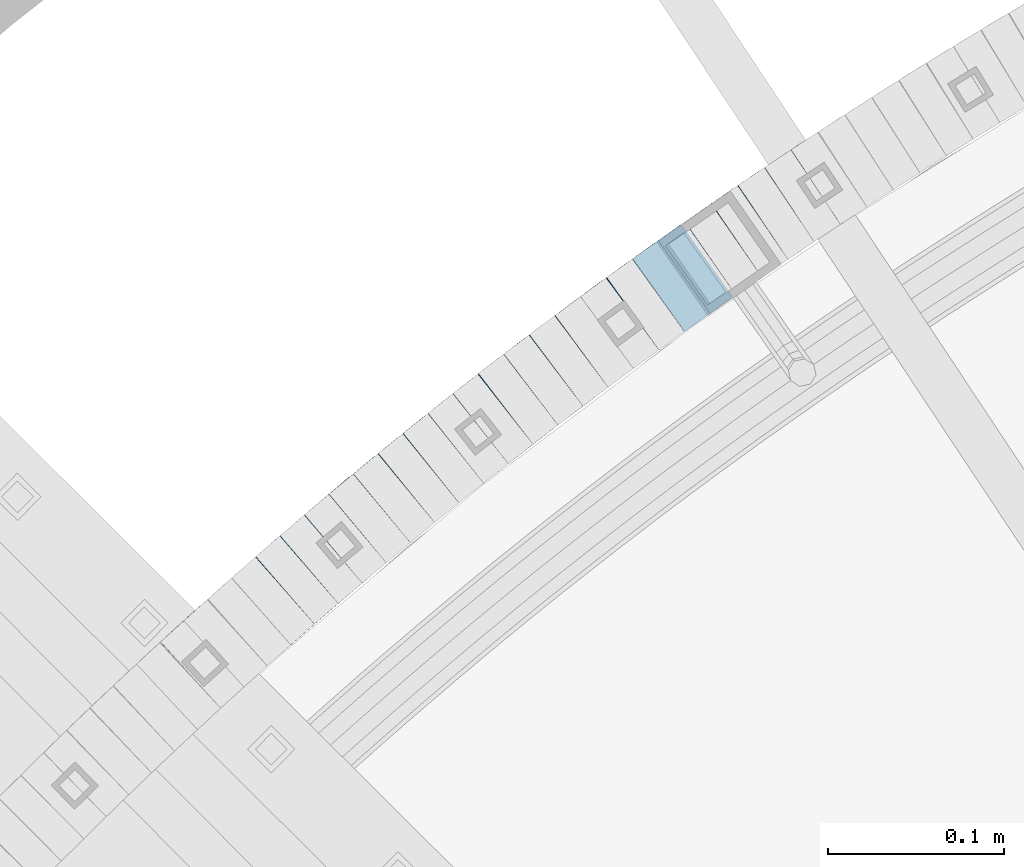
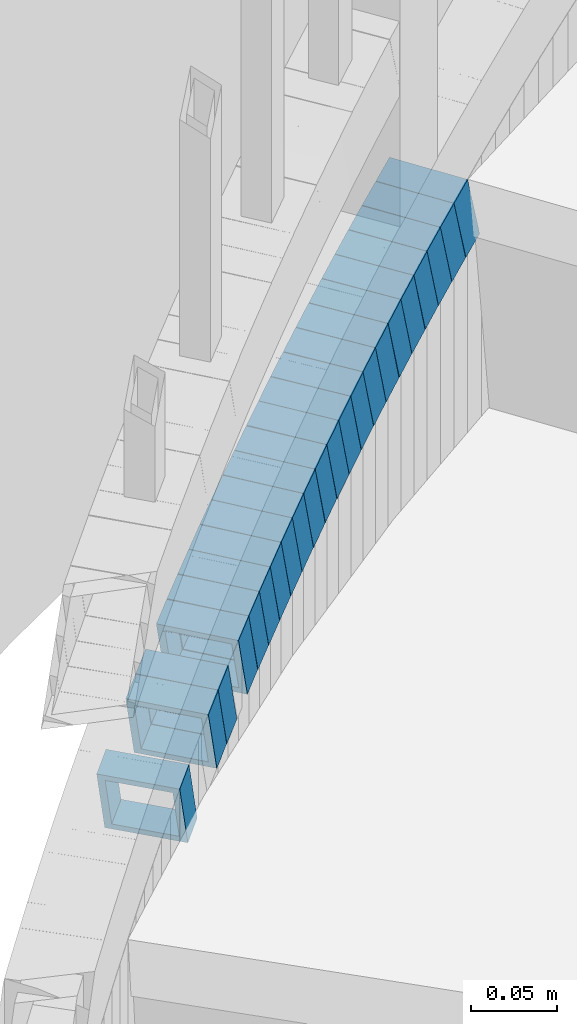
# One storey, part 744 of 975: 22 beams.
"""IFC2X3 building model written with IfcOpenShell, lengths in millimetres."""

from ifc_helpers import new_model, si_unit, frame, origin_with_axes, place, context, subcontext, project, spatial, faceted_brep, material, type_object, element, save


model = new_model("IFC2X3")

# Units and contexts
model_context = context("Model", 3, precision=1e-05, world=origin_with_axes())
body_context = subcontext(model_context, "Body", "Model", "MODEL_VIEW")
ifc_project = project(units=[si_unit("LENGTHUNIT", "METRE", prefix="MILLI"), si_unit("AREAUNIT", "SQUARE_METRE"), si_unit("VOLUMEUNIT", "CUBIC_METRE"), si_unit("MASSUNIT", "GRAM", prefix="KILO"), si_unit("TIMEUNIT", "SECOND"), si_unit("PLANEANGLEUNIT", "RADIAN"), si_unit("SOLIDANGLEUNIT", "STERADIAN"), si_unit("THERMODYNAMICTEMPERATUREUNIT", "DEGREE_CELSIUS"), si_unit("LUMINOUSINTENSITYUNIT", "LUMEN")], contexts=[model_context])

# Site, building, storey
site_placement = place(None, origin_with_axes())
site = spatial("IfcSite", under=ifc_project, at=site_placement, CompositionType="ELEMENT")
building_placement = place(site_placement, origin_with_axes())
building = spatial("IfcBuilding", under=site, at=building_placement, Name="Undefined", CompositionType="ELEMENT")
storey_placement = place(building_placement, origin_with_axes())
storey = spatial("IfcBuildingStorey", under=building, at=storey_placement, Name="Undefined", CompositionType="ELEMENT", Elevation=0.0)

# Beams
ifc_material = material()
beam_type = type_object("IfcBeamType", Name="HSS2X2X.188_TUBES", PredefinedType="NOTDEFINED")
beam_1_placement = place(storey_placement, frame((33156.9437501182, 5801.74871123698, 509.238198865219), z_axis=(0.553409530273966, -0.832909293862152, -1.71327656062203e-10), x_axis=(-0.792306643131029, -0.526431930086993, -0.308414666050958)))
element("IfcBeam", 1, at=beam_1_placement, inside=storey, type_object=beam_type, material=ifc_material, Name="WALL", ObjectType="HSS2X2X.188_TUBES", context=body_context, shape_type="Brep", body=[
    faceted_brep([(0.0, 20.6374999999753, -20.6375000000298), (0.0, -20.6375000000153, -20.6375000000153), (18.8066477608099, -20.6374999999862, -20.6375000000116), (18.8066477608172, 20.6375000000062, -20.6374999999971), (0.0, -20.6374999999825, 20.6375000000335), (18.8066477608463, -20.6375000000062, 20.6375000000407), (0.0, 20.6375000000116, 20.6375000000189), (18.8066477608536, 20.6374999999844, 20.637500000048), (0.0, 25.3999999999724, -25.4000000000342), (0.0, 25.400000000016, 25.4000000000196), (18.8066477608591, 25.3999999999814, 25.400000000056), (18.8066477608154, 25.4000000000051, -25.4000000000015), (0.0, -25.399999999976, 25.4000000000378), (18.8066477608518, -25.4000000000087, 25.4000000000451), (0.0, -25.400000000016, -25.4000000000196), (18.8066477608081, -25.3999999999851, -25.4000000000196)], [[[0, 1, 2, 3]], [[1, 4, 5, 2]], [[4, 6, 7, 5]], [[6, 0, 3, 7]], [[8, 9, 10, 11]], [[9, 12, 13, 10]], [[12, 14, 15, 13]], [[14, 8, 11, 15]], [[13, 15, 11, 10], [5, 7, 3, 2]], [[14, 12, 9, 8], [6, 4, 1, 0]]]),
])
beam_2_placement = place(storey_placement, frame((33141.8057865051, 5791.73312416079, 503.391923892116), z_axis=(0.557269559596288, -0.830331643349427, 9.54180450207788e-11), x_axis=(-0.791367387048939, -0.531119052032718, -0.30273785901866)))
element("IfcBeam", 2, at=beam_2_placement, inside=storey, type_object=beam_type, material=ifc_material, Name="WALL", ObjectType="HSS2X2X.188_TUBES", context=body_context, shape_type="Brep", body=[
    faceted_brep([(0.0, 20.6374999999753, -20.6375000000298), (0.0, -20.6375000000153, -20.6375000000153), (18.8332159191086, -20.6374999999916, -20.6375000000153), (18.8332159190923, 20.6375000000062, -20.6375000000335), (0.0, -20.6374999999825, 20.6375000000335), (18.8332159191377, -20.6375000000062, 20.6375000000335), (0.0, 20.6375000000116, 20.6375000000189), (18.8332159191141, 20.6374999999916, 20.6375000000116), (0.0, 25.3999999999724, -25.4000000000342), (0.0, 25.400000000016, 25.4000000000196), (18.8332159191159, 25.3999999999905, 25.4000000000124), (18.8332159190886, 25.4000000000069, -25.4000000000415), (0.0, -25.399999999976, 25.4000000000378), (18.8332159191395, -25.4000000000069, 25.4000000000378), (0.0, -25.400000000016, -25.4000000000196), (18.8332159191104, -25.3999999999905, -25.400000000016)], [[[0, 1, 2, 3]], [[1, 4, 5, 2]], [[4, 6, 7, 5]], [[6, 0, 3, 7]], [[8, 9, 10, 11]], [[9, 12, 13, 10]], [[12, 14, 15, 13]], [[14, 8, 11, 15]], [[13, 15, 11, 10], [5, 7, 3, 2]], [[14, 12, 9, 8], [6, 4, 1, 0]]]),
])
beam_3_placement = place(storey_placement, frame((33126.7181227514, 5781.67807316847, 497.695240339148), z_axis=(0.563683128984253, -0.825991119866626, 1.97794634004822e-11), x_axis=(-0.787122698810502, -0.537158057870734, -0.303148606927054)))
element("IfcBeam", 3, at=beam_3_placement, inside=storey, type_object=beam_type, material=ifc_material, Name="WALL", ObjectType="HSS2X2X.188_TUBES", context=body_context, shape_type="Brep", body=[
    faceted_brep([(0.0, 20.6374999999753, -20.6375000000298), (0.0, -20.6375000000153, -20.6375000000153), (18.8047866246379, -20.6374999999916, -20.6375000000298), (18.8047866247143, 20.6374999999844, -20.6374999999643), (0.0, -20.6374999999825, 20.6375000000335), (18.8047866247107, -20.6375000000189, 20.6375000000407), (0.0, 20.6375000000116, 20.6375000000189), (18.8047866247907, 20.6374999999589, 20.6375000001026), (0.0, 25.3999999999724, -25.4000000000342), (0.0, 25.400000000016, 25.4000000000196), (18.8047866248016, 25.3999999999542, 25.4000000001142), (18.8047866247143, 25.3999999999851, -25.3999999999651), (0.0, -25.399999999976, 25.4000000000378), (18.8047866247107, -25.4000000000196, 25.4000000000415), (0.0, -25.400000000016, -25.4000000000196), (18.8047866246197, -25.3999999999887, -25.4000000000378)], [[[0, 1, 2, 3]], [[1, 4, 5, 2]], [[4, 6, 7, 5]], [[6, 0, 3, 7]], [[8, 9, 10, 11]], [[9, 12, 13, 10]], [[12, 14, 15, 13]], [[14, 8, 11, 15]], [[13, 15, 11, 10], [5, 7, 3, 2]], [[14, 12, 9, 8], [6, 4, 1, 0]]]),
])
beam_4_placement = place(storey_placement, frame((33111.830593089, 5771.59106303628, 492.037804002505), z_axis=(0.570081548004454, -0.821588113731477, 5.08082393935182e-11), x_axis=(-0.781550119844909, -0.542300082892312, -0.308366713938778)))
element("IfcBeam", 4, at=beam_4_placement, inside=storey, type_object=beam_type, material=ifc_material, Name="WALL", ObjectType="HSS2X2X.188_TUBES", context=body_context, shape_type="Brep", body=[
    faceted_brep([(0.0, 20.6374999999753, -20.6375000000298), (0.0, -20.6375000000153, -20.6375000000153), (18.8066477608099, -20.6374999999862, -20.6375000000116), (18.8066477608172, 20.6375000000062, -20.6374999999971), (0.0, -20.6374999999825, 20.6375000000335), (18.8066477608463, -20.6375000000062, 20.6375000000407), (0.0, 20.6375000000116, 20.6375000000189), (18.8066477608536, 20.6374999999844, 20.637500000048), (0.0, 25.3999999999724, -25.4000000000342), (0.0, 25.400000000016, 25.4000000000196), (18.8066477608591, 25.3999999999814, 25.400000000056), (18.8066477608154, 25.4000000000051, -25.4000000000015), (0.0, -25.399999999976, 25.4000000000378), (18.8066477608518, -25.4000000000087, 25.4000000000451), (0.0, -25.400000000016, -25.4000000000196), (18.8066477608081, -25.3999999999851, -25.4000000000196)], [[[0, 1, 2, 3]], [[1, 4, 5, 2]], [[4, 6, 7, 5]], [[6, 0, 3, 7]], [[8, 9, 10, 11]], [[9, 12, 13, 10]], [[12, 14, 15, 13]], [[14, 8, 11, 15]], [[13, 15, 11, 10], [5, 7, 3, 2]], [[14, 12, 9, 8], [6, 4, 1, 0]]]),
])
beam_5_placement = place(storey_placement, frame((33096.8961195271, 5761.27087313172, 486.191338523111), z_axis=(0.573836192044239, -0.818970100003759, 1.08188942249399e-11), x_axis=(-0.780557870904746, -0.546921500933128, -0.302665296963004)))
element("IfcBeam", 5, at=beam_5_placement, inside=storey, type_object=beam_type, material=ifc_material, Name="WALL", ObjectType="HSS2X2X.188_TUBES", context=body_context, shape_type="Brep", body=[
    faceted_brep([(0.0, 20.6374999999753, -20.6375000000298), (0.0, -20.6375000000153, -20.6375000000153), (18.8332159191086, -20.6374999999916, -20.6375000000153), (18.8332159190923, 20.6375000000062, -20.6375000000335), (0.0, -20.6374999999825, 20.6375000000335), (18.8332159191377, -20.6375000000062, 20.6375000000335), (0.0, 20.6375000000116, 20.6375000000189), (18.8332159191141, 20.6374999999916, 20.6375000000116), (0.0, 25.3999999999724, -25.4000000000342), (0.0, 25.400000000016, 25.4000000000196), (18.8332159191159, 25.3999999999905, 25.4000000000124), (18.8332159190886, 25.4000000000069, -25.4000000000415), (0.0, -25.399999999976, 25.4000000000378), (18.8332159191395, -25.4000000000069, 25.4000000000378), (0.0, -25.400000000016, -25.4000000000196), (18.8332159191104, -25.3999999999905, -25.400000000016)], [[[0, 1, 2, 3]], [[1, 4, 5, 2]], [[4, 6, 7, 5]], [[6, 0, 3, 7]], [[8, 9, 10, 11]], [[9, 12, 13, 10]], [[12, 14, 15, 13]], [[14, 8, 11, 15]], [[13, 15, 11, 10], [5, 7, 3, 2]], [[14, 12, 9, 8], [6, 4, 1, 0]]]),
])
beam_6_placement = place(storey_placement, frame((33082.1861409827, 5751.02528155265, 480.551555677874), z_axis=(0.579108806712525, -0.815250262182108, -1.10815278731025e-10), x_axis=(-0.775079747055924, -0.550573889039712, -0.310031899022363)))
element("IfcBeam", 6, at=beam_6_placement, inside=storey, type_object=beam_type, material=ifc_material, Name="WALL", ObjectType="HSS2X2X.188_TUBES", context=body_context, shape_type="Brep", body=[
    faceted_brep([(0.0, 20.6374999999753, -20.6375000000298), (0.0, -20.6375000000153, -20.6375000000153), (18.7112265765609, -20.6375000000062, -20.6374999999862), (18.7112265765645, 20.6374999999898, -20.6374999999789), (0.0, -20.6374999999825, 20.6375000000335), (18.7112265765209, -20.6374999999916, 20.6374999999607), (0.0, 20.6375000000116, 20.6375000000189), (18.7112265765245, 20.6375000000025, 20.6374999999716), (0.0, 25.3999999999724, -25.4000000000342), (0.0, 25.400000000016, 25.4000000000196), (18.7112265765172, 25.4000000000051, 25.3999999999614), (18.7112265765718, 25.3999999999887, -25.3999999999724), (0.0, -25.399999999976, 25.4000000000378), (18.7112265765136, -25.3999999999905, 25.3999999999542), (0.0, -25.400000000016, -25.4000000000196), (18.7112265765682, -25.4000000000069, -25.3999999999796)], [[[0, 1, 2, 3]], [[1, 4, 5, 2]], [[4, 6, 7, 5]], [[6, 0, 3, 7]], [[8, 9, 10, 11]], [[9, 12, 13, 10]], [[12, 14, 15, 13]], [[14, 8, 11, 15]], [[13, 15, 11, 10], [5, 7, 3, 2]], [[14, 12, 9, 8], [6, 4, 1, 0]]]),
])
beam_7_placement = place(storey_placement, frame((33067.3758565744, 5740.55937547731, 474.687120284013), z_axis=(0.583865180861699, -0.811850633169264, -6.6912434704136e-11), x_axis=(-0.773907155204797, -0.55657706314726, -0.302141834079939)))
element("IfcBeam", 7, at=beam_7_placement, inside=storey, type_object=beam_type, material=ifc_material, Name="WALL", ObjectType="HSS2X2X.188_TUBES", context=body_context, shape_type="Brep", body=[
    faceted_brep([(0.0, 20.6374999999753, -20.6375000000298), (0.0, -20.6375000000153, -20.6375000000153), (18.8653120832787, -20.6374999999989, -20.6374999999935), (18.8653120832823, 20.6374999999971, -20.6374999999935), (0.0, -20.6374999999825, 20.6375000000335), (18.8653120833151, -20.6375000000116, 20.6375000000298), (0.0, 20.6375000000116, 20.6375000000189), (18.8653120833151, 20.6374999999844, 20.6375000000298), (0.0, 25.3999999999724, -25.4000000000342), (0.0, 25.400000000016, 25.4000000000196), (18.8653120833187, 25.3999999999814, 25.4000000000378), (18.8653120832823, 25.3999999999942, -25.3999999999905), (0.0, -25.399999999976, 25.4000000000378), (18.8653120833187, -25.4000000000124, 25.4000000000342), (0.0, -25.400000000016, -25.4000000000196), (18.8653120832787, -25.3999999999978, -25.3999999999942)], [[[0, 1, 2, 3]], [[1, 4, 5, 2]], [[4, 6, 7, 5]], [[6, 0, 3, 7]], [[8, 9, 10, 11]], [[9, 12, 13, 10]], [[12, 14, 15, 13]], [[14, 8, 11, 15]], [[13, 15, 11, 10], [5, 7, 3, 2]], [[14, 12, 9, 8], [6, 4, 1, 0]]]),
])
beam_8_placement = place(storey_placement, frame((33052.6627197005, 5730.03978821583, 469.007277447229), z_axis=(0.589172157703797, -0.80800753003091, 1.76057710632449e-10), x_axis=(-0.769602441062348, -0.561168447045414, -0.304634300024658)))
element("IfcBeam", 8, at=beam_8_placement, inside=storey, type_object=beam_type, material=ifc_material, Name="WALL", ObjectType="HSS2X2X.188_TUBES", context=body_context, shape_type="Brep", body=[
    faceted_brep([(0.0, 20.6374999999753, -20.6375000000298), (0.0, -20.6375000000153, -20.6375000000153), (18.7112265765609, -20.6375000000062, -20.6374999999862), (18.7112265765645, 20.6374999999898, -20.6374999999789), (0.0, -20.6374999999825, 20.6375000000335), (18.7112265765209, -20.6374999999916, 20.6374999999607), (0.0, 20.6375000000116, 20.6375000000189), (18.7112265765245, 20.6375000000025, 20.6374999999716), (0.0, 25.3999999999724, -25.4000000000342), (0.0, 25.400000000016, 25.4000000000196), (18.7112265765172, 25.4000000000051, 25.3999999999614), (18.7112265765718, 25.3999999999887, -25.3999999999724), (0.0, -25.399999999976, 25.4000000000378), (18.7112265765136, -25.3999999999905, 25.3999999999542), (0.0, -25.400000000016, -25.4000000000196), (18.7112265765682, -25.4000000000069, -25.3999999999796)], [[[0, 1, 2, 3]], [[1, 4, 5, 2]], [[4, 6, 7, 5]], [[6, 0, 3, 7]], [[8, 9, 10, 11]], [[9, 12, 13, 10]], [[12, 14, 15, 13]], [[14, 8, 11, 15]], [[13, 15, 11, 10], [5, 7, 3, 2]], [[14, 12, 9, 8], [6, 4, 1, 0]]]),
])
beam_9_placement = place(storey_placement, frame((33038.0980053318, 5719.50551526245, 463.331662397714), z_axis=(0.596426622612838, -0.802667604826957, -6.71022917231312e-11), x_axis=(-0.763745734904415, -0.567505510928847, -0.307619809961425)))
element("IfcBeam", 9, at=beam_9_placement, inside=storey, type_object=beam_type, material=ifc_material, Name="WALL", ObjectType="HSS2X2X.188_TUBES", context=body_context, shape_type="Brep", body=[
    faceted_brep([(0.0, 20.6374999999753, -20.6375000000298), (0.0, -20.6375000000153, -20.6375000000153), (18.8480768248774, -20.6374999999716, -20.6375000000735), (18.8480768249356, 20.6375000000153, -20.6375000000226), (0.0, -20.6374999999825, 20.6375000000335), (18.8480768249283, -20.6374999999935, 20.6374999999716), (0.0, 20.6375000000116, 20.6375000000189), (18.8480768249865, 20.6374999999935, 20.6375000000262), (0.0, 25.3999999999724, -25.4000000000342), (0.0, 25.400000000016, 25.4000000000196), (18.848076825001, 25.3999999999887, 25.4000000000378), (18.8480768249392, 25.4000000000142, -25.4000000000233), (0.0, -25.399999999976, 25.4000000000378), (18.8480768249283, -25.399999999996, 25.3999999999833), (0.0, -25.400000000016, -25.4000000000196), (18.8480768248664, -25.3999999999687, -25.4000000000779)], [[[0, 1, 2, 3]], [[1, 4, 5, 2]], [[4, 6, 7, 5]], [[6, 0, 3, 7]], [[8, 9, 10, 11]], [[9, 12, 13, 10]], [[12, 14, 15, 13]], [[14, 8, 11, 15]], [[13, 15, 11, 10], [5, 7, 3, 2]], [[14, 12, 9, 8], [6, 4, 1, 0]]]),
])
beam_10_placement = place(storey_placement, frame((33023.4827001943, 5708.70963073527, 457.512531166684), z_axis=(0.601798252138622, -0.798648147636304, 1.05659012206161e-10), x_axis=(-0.760522724125057, -0.573069940094374, -0.305280248050268)))
element("IfcBeam", 10, at=beam_10_placement, inside=storey, type_object=beam_type, material=ifc_material, Name="WALL", ObjectType="HSS2X2X.188_TUBES", context=body_context, shape_type="Brep", body=[
    faceted_brep([(0.0, 20.6374999999753, -20.6375000000298), (0.0, -20.6375000000153, -20.6375000000153), (18.6689581926366, -20.6374999999953, -20.6374999999916), (18.6689581926476, 20.6375000000062, -20.6374999999935), (0.0, -20.6374999999825, 20.6375000000335), (18.6689581927276, -20.6375000000116, 20.6374999999862), (0.0, 20.6375000000116, 20.6375000000189), (18.6689581927312, 20.6374999999862, 20.6374999999844), (0.0, 25.3999999999724, -25.4000000000342), (0.0, 25.400000000016, 25.4000000000196), (18.6689581927458, 25.3999999999833, 25.3999999999814), (18.6689581926366, 25.4000000000087, -25.3999999999905), (0.0, -25.399999999976, 25.4000000000378), (18.6689581927385, -25.4000000000142, 25.3999999999851), (0.0, -25.400000000016, -25.4000000000196), (18.6689581926257, -25.3999999999887, -25.3999999999869)], [[[0, 1, 2, 3]], [[1, 4, 5, 2]], [[4, 6, 7, 5]], [[6, 0, 3, 7]], [[8, 9, 10, 11]], [[9, 12, 13, 10]], [[12, 14, 15, 13]], [[14, 8, 11, 15]], [[13, 15, 11, 10], [5, 7, 3, 2]], [[14, 12, 9, 8], [6, 4, 1, 0]]]),
])
beam_11_placement = place(storey_placement, frame((33009.2113951405, 5697.96647127917, 451.794963263876), z_axis=(0.602675192946117, -0.797986598764266, 3.15118882099341e-11), x_axis=(-0.760444683064147, -0.574321858048485, -0.303114314025594)))
element("IfcBeam", 11, at=beam_11_placement, inside=storey, type_object=beam_type, material=ifc_material, Name="WALL", ObjectType="HSS2X2X.188_TUBES", context=body_context, shape_type="Brep", body=[
    faceted_brep([(0.0, 20.6374999999753, -20.6375000000298), (0.0, -20.6375000000153, -20.6375000000153), (18.8047866246379, -20.6374999999916, -20.6375000000298), (18.8047866247143, 20.6374999999844, -20.6374999999643), (0.0, -20.6374999999825, 20.6375000000335), (18.8047866247107, -20.6375000000189, 20.6375000000407), (0.0, 20.6375000000116, 20.6375000000189), (18.8047866247907, 20.6374999999589, 20.6375000001026), (0.0, 25.3999999999724, -25.4000000000342), (0.0, 25.400000000016, 25.4000000000196), (18.8047866248016, 25.3999999999542, 25.4000000001142), (18.8047866247143, 25.3999999999851, -25.3999999999651), (0.0, -25.399999999976, 25.4000000000378), (18.8047866247107, -25.4000000000196, 25.4000000000415), (0.0, -25.400000000016, -25.4000000000196), (18.8047866246197, -25.3999999999887, -25.4000000000378)], [[[0, 1, 2, 3]], [[1, 4, 5, 2]], [[4, 6, 7, 5]], [[6, 0, 3, 7]], [[8, 9, 10, 11]], [[9, 12, 13, 10]], [[12, 14, 15, 13]], [[14, 8, 11, 15]], [[13, 15, 11, 10], [5, 7, 3, 2]], [[14, 12, 9, 8], [6, 4, 1, 0]]]),
])
beam_12_placement = place(storey_placement, frame((32994.7596265259, 5687.16056435424, 446.146877247052), z_axis=(0.611607182686762, -0.791161585319941, -1.44334649121447e-10), x_axis=(-0.752323736267157, -0.581583597206622, -0.309466501109943)))
element("IfcBeam", 12, at=beam_12_placement, inside=storey, type_object=beam_type, material=ifc_material, Name="WALL", ObjectType="HSS2X2X.188_TUBES", context=body_context, shape_type="Brep", body=[
    faceted_brep([(0.0, 20.6374999999753, -20.6375000000298), (0.0, -20.6375000000153, -20.6375000000153), (18.7416648140024, -20.6375000000153, -20.6374999999825), (18.7416648139188, 20.6375000000189, -20.6375000000298), (0.0, -20.6374999999825, 20.6375000000335), (18.7416648140097, -20.6375000000189, 20.6375000000226), (0.0, 20.6375000000116, 20.6375000000189), (18.741664813926, 20.6375000000153, 20.6374999999753), (0.0, 25.3999999999724, -25.4000000000342), (0.0, 25.400000000016, 25.4000000000196), (18.7416648139224, 25.4000000000196, 25.3999999999687), (18.7416648139042, 25.4000000000233, -25.4000000000378), (0.0, -25.399999999976, 25.4000000000378), (18.7416648140133, -25.4000000000215, 25.4000000000269), (0.0, -25.400000000016, -25.4000000000196), (18.7416648140133, -25.4000000000196, -25.399999999976)], [[[0, 1, 2, 3]], [[1, 4, 5, 2]], [[4, 6, 7, 5]], [[6, 0, 3, 7]], [[8, 9, 10, 11]], [[9, 12, 13, 10]], [[12, 14, 15, 13]], [[14, 8, 11, 15]], [[13, 15, 11, 10], [5, 7, 3, 2]], [[14, 12, 9, 8], [6, 4, 1, 0]]]),
])
beam_13_placement = place(storey_placement, frame((32980.4336947195, 5676.12872632998, 440.299551513587), z_axis=(0.615101329330327, -0.788448067190265, 4.57119426755526e-11), x_axis=(-0.751212474107848, -0.586052285084287, -0.303681639043674)))
element("IfcBeam", 13, at=beam_13_placement, inside=storey, type_object=beam_type, material=ifc_material, Name="WALL", ObjectType="HSS2X2X.188_TUBES", context=body_context, shape_type="Brep", body=[
    faceted_brep([(0.0, 20.6374999999753, -20.6375000000298), (0.0, -20.6375000000153, -20.6375000000153), (18.767258723612, -20.6375000000025, -20.6374999999862), (18.7672587236229, 20.6374999999953, -20.637499999968), (0.0, -20.6374999999825, 20.6375000000335), (18.767258723612, -20.6375000000135, 20.6375000000153), (0.0, 20.6375000000116, 20.6375000000189), (18.7672587236266, 20.6374999999844, 20.6375000000371), (0.0, 25.3999999999724, -25.4000000000342), (0.0, 25.400000000016, 25.4000000000196), (18.7672587236302, 25.3999999999814, 25.4000000000342), (18.7672587236229, 25.399999999996, -25.3999999999687), (0.0, -25.399999999976, 25.4000000000378), (18.7672587236157, -25.4000000000142, 25.400000000016), (0.0, -25.400000000016, -25.4000000000196), (18.767258723612, -25.4000000000015, -25.3999999999905)], [[[0, 1, 2, 3]], [[1, 4, 5, 2]], [[4, 6, 7, 5]], [[6, 0, 3, 7]], [[8, 9, 10, 11]], [[9, 12, 13, 10]], [[12, 14, 15, 13]], [[14, 8, 11, 15]], [[13, 15, 11, 10], [5, 7, 3, 2]], [[14, 12, 9, 8], [6, 4, 1, 0]]]),
])
beam_14_placement = place(storey_placement, frame((32966.1445457427, 5665.05708913754, 434.601648756833), z_axis=(0.621276225268784, -0.783591635940412, 7.90051899457469e-11), x_axis=(-0.746520694738068, -0.591884264792206, -0.3039405688933)))
element("IfcBeam", 14, at=beam_14_placement, inside=storey, type_object=beam_type, material=ifc_material, Name="WALL", ObjectType="HSS2X2X.188_TUBES", context=body_context, shape_type="Brep", body=[
    faceted_brep([(0.0, 20.6374999999753, -20.6375000000298), (0.0, -20.6375000000153, -20.6375000000153), (18.7547327359644, -20.6374999999844, -20.6375000000553), (18.7547327359898, 20.6375000000171, -20.6375000000335), (0.0, -20.6374999999825, 20.6375000000335), (18.7547327360044, -20.6374999999953, 20.6374999999898), (0.0, 20.6375000000116, 20.6375000000189), (18.7547327360262, 20.6375000000062, 20.6375000000116), (0.0, 25.3999999999724, -25.4000000000342), (0.0, 25.400000000016, 25.4000000000196), (18.7547327360371, 25.4000000000033, 25.4000000000124), (18.7547327359898, 25.4000000000178, -25.4000000000342), (0.0, -25.399999999976, 25.4000000000378), (18.7547327360044, -25.399999999996, 25.3999999999869), (0.0, -25.400000000016, -25.4000000000196), (18.7547327359498, -25.3999999999814, -25.4000000000597)], [[[0, 1, 2, 3]], [[1, 4, 5, 2]], [[4, 6, 7, 5]], [[6, 0, 3, 7]], [[8, 9, 10, 11]], [[9, 12, 13, 10]], [[12, 14, 15, 13]], [[14, 8, 11, 15]], [[13, 15, 11, 10], [5, 7, 3, 2]], [[14, 12, 9, 8], [6, 4, 1, 0]]]),
])
beam_15_placement = place(storey_placement, frame((32952.0824100639, 5653.94217407256, 428.91149812081), z_axis=(0.624009233126315, -0.781416967420793, -5.25109271620749e-11), x_axis=(-0.744145897469352, -0.594246004576279, -0.305153353782426)))
element("IfcBeam", 15, at=beam_15_placement, inside=storey, type_object=beam_type, material=ifc_material, Name="WALL", ObjectType="HSS2X2X.188_TUBES", context=body_context, shape_type="Brep", body=[
    faceted_brep([(0.0, 20.6374999999753, -20.6375000000298), (0.0, -20.6375000000153, -20.6375000000153), (18.677794302308, -20.6374999999989, -20.6374999999862), (18.6777943022862, 20.6375000000098, -20.6375000000153), (0.0, -20.6374999999825, 20.6375000000335), (18.6777943022862, -20.6375000000044, 20.6374999999862), (0.0, 20.6375000000116, 20.6375000000189), (18.6777943022644, 20.6375000000044, 20.6374999999571), (0.0, 25.3999999999724, -25.4000000000342), (0.0, 25.400000000016, 25.4000000000196), (18.6777943022607, 25.4000000000033, 25.3999999999505), (18.6777943022898, 25.4000000000124, -25.400000000016), (0.0, -25.399999999976, 25.4000000000378), (18.6777943022862, -25.4000000000069, 25.3999999999905), (0.0, -25.400000000016, -25.4000000000196), (18.6777943023117, -25.3999999999978, -25.3999999999796)], [[[0, 1, 2, 3]], [[1, 4, 5, 2]], [[4, 6, 7, 5]], [[6, 0, 3, 7]], [[8, 9, 10, 11]], [[9, 12, 13, 10]], [[12, 14, 15, 13]], [[14, 8, 11, 15]], [[13, 15, 11, 10], [5, 7, 3, 2]], [[14, 12, 9, 8], [6, 4, 1, 0]]]),
])
beam_16_placement = place(storey_placement, frame((32938.0241566757, 5642.80191429727, 423.235047003459), z_axis=(0.630802760326158, -0.775943218003031, 8.13225256024453e-11), x_axis=(-0.738213834772739, -0.600130671815258, -0.308031671905169)))
element("IfcBeam", 16, at=beam_16_placement, inside=storey, type_object=beam_type, material=ifc_material, Name="WALL", ObjectType="HSS2X2X.188_TUBES", context=body_context, shape_type="Brep", body=[
    faceted_brep([(0.0, 20.6374999999753, -20.6375000000298), (0.0, -20.6375000000153, -20.6375000000153), (18.8332159191086, -20.6374999999916, -20.6375000000153), (18.8332159190923, 20.6375000000062, -20.6375000000335), (0.0, -20.6374999999825, 20.6375000000335), (18.8332159191377, -20.6375000000062, 20.6375000000335), (0.0, 20.6375000000116, 20.6375000000189), (18.8332159191141, 20.6374999999916, 20.6375000000116), (0.0, 25.3999999999724, -25.4000000000342), (0.0, 25.400000000016, 25.4000000000196), (18.8332159191159, 25.3999999999905, 25.4000000000124), (18.8332159190886, 25.4000000000069, -25.4000000000415), (0.0, -25.399999999976, 25.4000000000378), (18.8332159191395, -25.4000000000069, 25.4000000000378), (0.0, -25.400000000016, -25.4000000000196), (18.8332159191104, -25.3999999999905, -25.400000000016)], [[[0, 1, 2, 3]], [[1, 4, 5, 2]], [[4, 6, 7, 5]], [[6, 0, 3, 7]], [[8, 9, 10, 11]], [[9, 12, 13, 10]], [[12, 14, 15, 13]], [[14, 8, 11, 15]], [[13, 15, 11, 10], [5, 7, 3, 2]], [[14, 12, 9, 8], [6, 4, 1, 0]]]),
])
beam_17_placement = place(storey_placement, frame((32923.965853792, 5631.40825857689, 417.405442344623), z_axis=(0.633543049808969, -0.773707440857816, -1.84472810360603e-11), x_axis=(-0.736988555083811, -0.603476136068711, -0.304408316034656)))
element("IfcBeam", 17, at=beam_17_placement, inside=storey, type_object=beam_type, material=ifc_material, Name="WALL", ObjectType="HSS2X2X.188_TUBES", context=body_context, shape_type="Brep", body=[
    faceted_brep([(0.0, 20.6374999999753, -20.6375000000298), (0.0, -20.6375000000153, -20.6375000000153), (18.724849799155, -20.6375000000171, -20.6374999999425), (18.7248497991204, 20.6374999999989, -20.6375000000007), (0.0, -20.6374999999825, 20.6375000000335), (18.7248497991168, -20.6374999999953, 20.6375000000007), (0.0, 20.6375000000116, 20.6375000000189), (18.724849799084, 20.6375000000226, 20.6374999999498), (0.0, 25.3999999999724, -25.4000000000342), (0.0, 25.400000000016, 25.4000000000196), (18.7248497990731, 25.4000000000269, 25.399999999936), (18.7248497991204, 25.3999999999978, -25.3999999999978), (0.0, -25.399999999976, 25.4000000000378), (18.7248497991186, -25.3999999999942, 25.4000000000051), (0.0, -25.400000000016, -25.4000000000196), (18.7248497991604, -25.4000000000233, -25.3999999999323)], [[[0, 1, 2, 3]], [[1, 4, 5, 2]], [[4, 6, 7, 5]], [[6, 0, 3, 7]], [[8, 9, 10, 11]], [[9, 12, 13, 10]], [[12, 14, 15, 13]], [[14, 8, 11, 15]], [[13, 15, 11, 10], [5, 7, 3, 2]], [[14, 12, 9, 8], [6, 4, 1, 0]]]),
])
beam_18_placement = place(storey_placement, frame((32909.9763935626, 5620.03105763535, 411.707136087588), z_axis=(0.639632351351478, -0.768680983961864, -1.5163004718488e-10), x_axis=(-0.73214938788909, -0.609233796907725, -0.304616897953853)))
element("IfcBeam", 18, at=beam_18_placement, inside=storey, type_object=beam_type, material=ifc_material, Name="WALL", ObjectType="HSS2X2X.188_TUBES", context=body_context, shape_type="Brep", body=[
    faceted_brep([(0.0, 20.6374999999753, -20.6375000000298), (0.0, -20.6375000000153, -20.6375000000153), (18.7112265765609, -20.6375000000062, -20.6374999999862), (18.7112265765645, 20.6374999999898, -20.6374999999789), (0.0, -20.6374999999825, 20.6375000000335), (18.7112265765209, -20.6374999999916, 20.6374999999607), (0.0, 20.6375000000116, 20.6375000000189), (18.7112265765245, 20.6375000000025, 20.6374999999716), (0.0, 25.3999999999724, -25.4000000000342), (0.0, 25.400000000016, 25.4000000000196), (18.7112265765172, 25.4000000000051, 25.3999999999614), (18.7112265765718, 25.3999999999887, -25.3999999999724), (0.0, -25.399999999976, 25.4000000000378), (18.7112265765136, -25.3999999999905, 25.3999999999542), (0.0, -25.400000000016, -25.4000000000196), (18.7112265765682, -25.4000000000069, -25.3999999999796)], [[[0, 1, 2, 3]], [[1, 4, 5, 2]], [[4, 6, 7, 5]], [[6, 0, 3, 7]], [[8, 9, 10, 11]], [[9, 12, 13, 10]], [[12, 14, 15, 13]], [[14, 8, 11, 15]], [[13, 15, 11, 10], [5, 7, 3, 2]], [[14, 12, 9, 8], [6, 4, 1, 0]]]),
])
beam_19_placement = place(storey_placement, frame((32895.963439769, 5608.4904553108, 406.000564266117), z_axis=(0.648946606019702, -0.760833952012862, -4.31282387580723e-12), x_axis=(-0.724872139285838, -0.618273295243668, -0.303806705119734)))
element("IfcBeam", 19, at=beam_19_placement, inside=storey, type_object=beam_type, material=ifc_material, Name="WALL", ObjectType="HSS2X2X.188_TUBES", context=body_context, shape_type="Brep", body=[
    faceted_brep([(0.0, 20.6374999999753, -20.6375000000298), (0.0, -20.6375000000153, -20.6375000000153), (18.7555325170906, -20.6374999999916, -20.6374999999971), (18.7555325171452, 20.637499999988, -20.6374999999571), (0.0, -20.6374999999825, 20.6375000000335), (18.7555325170615, -20.6374999999844, 20.6374999999716), (0.0, 20.6375000000116, 20.6375000000189), (18.7555325171015, 20.6374999999953, 20.637500000008), (0.0, 25.3999999999724, -25.4000000000342), (0.0, 25.400000000016, 25.4000000000196), (18.7555325171015, 25.399999999996, 25.4000000000051), (18.7555325171488, 25.3999999999851, -25.3999999999505), (0.0, -25.399999999976, 25.4000000000378), (18.755532517047, -25.3999999999814, 25.3999999999578), (0.0, -25.400000000016, -25.4000000000196), (18.7555325170979, -25.3999999999924, -25.3999999999978)], [[[0, 1, 2, 3]], [[1, 4, 5, 2]], [[4, 6, 7, 5]], [[6, 0, 3, 7]], [[8, 9, 10, 11]], [[9, 12, 13, 10]], [[12, 14, 15, 13]], [[14, 8, 11, 15]], [[13, 15, 11, 10], [5, 7, 3, 2]], [[14, 12, 9, 8], [6, 4, 1, 0]]]),
])
beam_20_placement = place(storey_placement, frame((32868.5748966277, 5585.208681875, 394.501893913719), z_axis=(0.654930538567627, -0.755689082660004, 2.07912648875208e-10), x_axis=(-0.719930889850491, -0.623940104870603, -0.303970819936951)))
element("IfcBeam", 20, at=beam_20_placement, inside=storey, type_object=beam_type, material=ifc_material, Name="WALL", ObjectType="HSS2X2X.188_TUBES", context=body_context, shape_type="Brep", body=[
    faceted_brep([(0.0, 20.6374999999753, -20.6375000000298), (0.0, -20.6375000000153, -20.6375000000153), (18.7547327359644, -20.6374999999844, -20.6375000000553), (18.7547327359898, 20.6375000000171, -20.6375000000335), (0.0, -20.6374999999825, 20.6375000000335), (18.7547327360044, -20.6374999999953, 20.6374999999898), (0.0, 20.6375000000116, 20.6375000000189), (18.7547327360262, 20.6375000000062, 20.6375000000116), (0.0, 25.3999999999724, -25.4000000000342), (0.0, 25.400000000016, 25.4000000000196), (18.7547327360371, 25.4000000000033, 25.4000000000124), (18.7547327359898, 25.4000000000178, -25.4000000000342), (0.0, -25.399999999976, 25.4000000000378), (18.7547327360044, -25.399999999996, 25.3999999999869), (0.0, -25.400000000016, -25.4000000000196), (18.7547327359498, -25.3999999999814, -25.4000000000597)], [[[0, 1, 2, 3]], [[1, 4, 5, 2]], [[4, 6, 7, 5]], [[6, 0, 3, 7]], [[8, 9, 10, 11]], [[9, 12, 13, 10]], [[12, 14, 15, 13]], [[14, 8, 11, 15]], [[13, 15, 11, 10], [5, 7, 3, 2]], [[14, 12, 9, 8], [6, 4, 1, 0]]]),
])
beam_21_placement = place(storey_placement, frame((32854.8864427702, 5573.42506379421, 388.803086098855), z_axis=(0.660880367955666, -0.75049126527281, -6.81784513290041e-11), x_axis=(-0.714943800930225, -0.629577376938425, -0.304117884970246)))
element("IfcBeam", 21, at=beam_21_placement, inside=storey, type_object=beam_type, material=ifc_material, Name="WALL", ObjectType="HSS2X2X.188_TUBES", context=body_context, shape_type="Brep", body=[
    faceted_brep([(0.0, 20.6374999999753, -20.6375000000298), (0.0, -20.6375000000153, -20.6375000000153), (18.7416648140024, -20.6375000000153, -20.6374999999825), (18.7416648139188, 20.6375000000189, -20.6375000000298), (0.0, -20.6374999999825, 20.6375000000335), (18.7416648140097, -20.6375000000189, 20.6375000000226), (0.0, 20.6375000000116, 20.6375000000189), (18.741664813926, 20.6375000000153, 20.6374999999753), (0.0, 25.3999999999724, -25.4000000000342), (0.0, 25.400000000016, 25.4000000000196), (18.7416648139224, 25.4000000000196, 25.3999999999687), (18.7416648139042, 25.4000000000233, -25.4000000000378), (0.0, -25.399999999976, 25.4000000000378), (18.7416648140133, -25.4000000000215, 25.4000000000269), (0.0, -25.400000000016, -25.4000000000196), (18.7416648140133, -25.4000000000196, -25.399999999976)], [[[0, 1, 2, 3]], [[1, 4, 5, 2]], [[4, 6, 7, 5]], [[6, 0, 3, 7]], [[8, 9, 10, 11]], [[9, 12, 13, 10]], [[12, 14, 15, 13]], [[14, 8, 11, 15]], [[13, 15, 11, 10], [5, 7, 3, 2]], [[14, 12, 9, 8], [6, 4, 1, 0]]]),
])
beam_22_placement = place(storey_placement, frame((32814.409972724, 5537.65230182008, 371.605054865329), z_axis=(0.672672794095991, -0.739940073305327, 8.58585735841189e-11), x_axis=(-0.704835019237665, -0.640759108216156, -0.304360577102682)))
element("IfcBeam", 22, at=beam_22_placement, inside=storey, type_object=beam_type, material=ifc_material, Name="WALL", ObjectType="HSS2X2X.188_TUBES", context=body_context, shape_type="Brep", body=[
    faceted_brep([(0.0, 20.6374999999753, -20.6375000000298), (0.0, -20.6375000000153, -20.6375000000153), (18.7347271129966, -20.6375000000116, -20.6375000000262), (18.7347271130257, 20.6374999999989, -20.6374999999935), (0.0, -20.6374999999825, 20.6375000000335), (18.7347271129947, -20.6375000000116, 20.6374999999607), (0.0, 20.6375000000116, 20.6375000000189), (18.7347271130147, 20.6375000000007, 20.6374999999898), (0.0, 25.3999999999724, -25.4000000000342), (0.0, 25.400000000016, 25.4000000000196), (18.7347271130166, 25.4000000000015, 25.3999999999905), (18.7347271130257, 25.3999999999996, -25.3999999999869), (0.0, -25.399999999976, 25.4000000000378), (18.7347271129875, -25.4000000000106, 25.3999999999505), (0.0, -25.400000000016, -25.4000000000196), (18.7347271130002, -25.4000000000124, -25.4000000000233)], [[[0, 1, 2, 3]], [[1, 4, 5, 2]], [[4, 6, 7, 5]], [[6, 0, 3, 7]], [[8, 9, 10, 11]], [[9, 12, 13, 10]], [[12, 14, 15, 13]], [[14, 8, 11, 15]], [[13, 15, 11, 10], [5, 7, 3, 2]], [[14, 12, 9, 8], [6, 4, 1, 0]]]),
])

save(model, "model.ifc")
